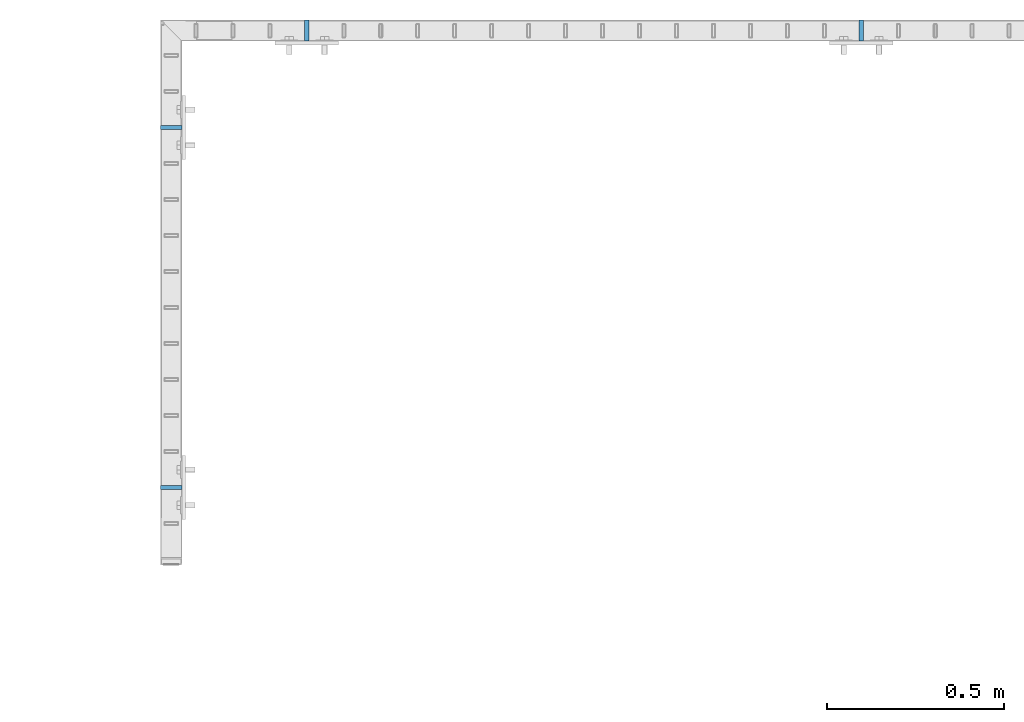
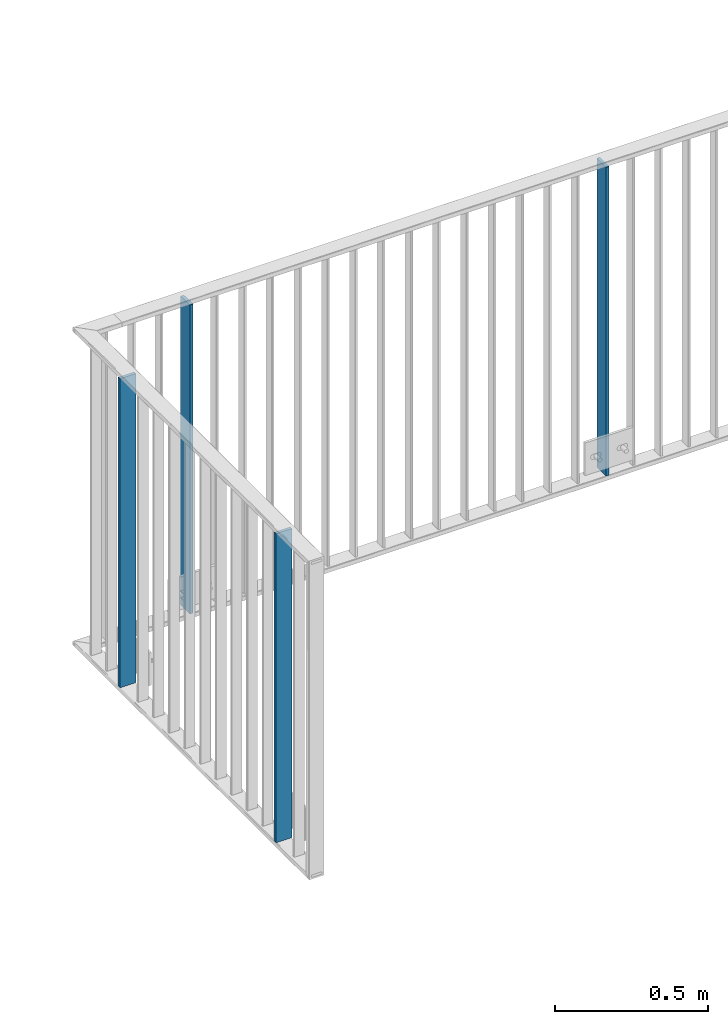
# One storey, part 41 of 156: 4 plates, 2 elements without a shape of their own.
"""IFC2X3 building model written with IfcOpenShell, lengths in millimetres."""

from ifc_helpers import new_model, si_unit, frame, origin_with_axes, origin_2d_with_axis, place, context, subcontext, project, spatial, rectangle, extrude, material, type_object, element, aggregate, save


model = new_model("IFC2X3")

# Units and contexts
model_context = context("Model", 3, precision=1e-05, world=origin_with_axes())
body_context = subcontext(model_context, "Body", "Model", "MODEL_VIEW")
ifc_project = project(units=[si_unit("LENGTHUNIT", "METRE", prefix="MILLI"), si_unit("AREAUNIT", "SQUARE_METRE"), si_unit("VOLUMEUNIT", "CUBIC_METRE"), si_unit("MASSUNIT", "GRAM", prefix="KILO"), si_unit("TIMEUNIT", "SECOND"), si_unit("PLANEANGLEUNIT", "RADIAN"), si_unit("SOLIDANGLEUNIT", "STERADIAN"), si_unit("THERMODYNAMICTEMPERATUREUNIT", "DEGREE_CELSIUS"), si_unit("LUMINOUSINTENSITYUNIT", "LUMEN")], contexts=[model_context])

# Site, building, storey
site_placement = place(None, origin_with_axes())
site = spatial("IfcSite", under=ifc_project, at=site_placement, CompositionType="ELEMENT")
building_placement = place(site_placement, origin_with_axes())
building = spatial("IfcBuilding", under=site, at=building_placement, Name="Undefined", CompositionType="ELEMENT")
storey_placement = place(building_placement, origin_with_axes())
storey = spatial("IfcBuildingStorey", under=building, at=storey_placement, Name="Undefined", CompositionType="ELEMENT", Elevation=0.0)

# Assembly, plate
assembly_1_placement = place(storey_placement, origin_with_axes())
assembly_1 = element("IfcElementAssembly", 1, at=assembly_1_placement, inside=storey, AssemblyPlace="NOTDEFINED", PredefinedType="RIGID_FRAME")
ifc_material = material(Name="STEEL/S235JR")
plate_type = type_object("IfcPlateType", PredefinedType="NOTDEFINED")
plate_1_placement = place(assembly_1_placement, frame((21874.9983592497, 22766.5810137578, 3980.00000000003), z_axis=(1.0, 0.0, 0.0), x_axis=(0.0, 0.0, -1.0)))
plate_1 = element("IfcPlate", 2, at=plate_1_placement, type_object=plate_type, material=ifc_material, context=body_context, shape_type="SweptSolid", body=[
    extrude(rectangle(XDim=12.0, YDim=60.0, at=origin_2d_with_axis()), frame((1230.0, 0.0, 0.0), z_axis=(-1.0, 0.0, 0.0), x_axis=(0.0, -1.0, 0.0)), (0.0, 0.0, 1.0), 1230.0),
])

# Assembly, plates
assembly_2_placement = place(storey_placement, origin_with_axes())
assembly_2 = element("IfcElementAssembly", 3, at=assembly_2_placement, inside=storey, AssemblyPlace="NOTDEFINED", PredefinedType="RIGID_FRAME")
plate_2_placement = place(assembly_2_placement, frame((23825.3401831972, 24057.9916060596, 3980.00000000003), z_axis=(0.0, -1.0, 0.0), x_axis=(0.0, 0.0, -1.0)))
plate_2 = element("IfcPlate", 4, at=plate_2_placement, type_object=plate_type, material=ifc_material, context=body_context, shape_type="SweptSolid", body=[
    extrude(rectangle(XDim=12.0, YDim=60.0, at=origin_2d_with_axis()), frame((1230.0, 0.0, 0.0), z_axis=(-1.0, 0.0, 0.0), x_axis=(0.0, -1.0, 0.0)), (0.0, 0.0, 1.0), 1230.0),
])
plate_3_placement = place(assembly_2_placement, frame((22258.3187312877, 24057.9916060596, 3980.00000000003), z_axis=(0.0, -1.0, 0.0), x_axis=(0.0, 0.0, -1.0)))
plate_3 = element("IfcPlate", 5, at=plate_3_placement, type_object=plate_type, material=ifc_material, context=body_context, shape_type="SweptSolid", body=[
    extrude(rectangle(XDim=12.0, YDim=60.0, at=origin_2d_with_axis()), frame((1230.0, 0.0, 0.0), z_axis=(-1.0, 0.0, 0.0), x_axis=(0.0, -1.0, 0.0)), (0.0, 0.0, 1.0), 1230.0),
])
aggregate(assembly_2, [plate_2, plate_3])

# Plate
plate_4_placement = place(assembly_1_placement, frame((21874.9983592497, 23784.4303835178, 3980.00000000003), z_axis=(1.0, 0.0, 0.0), x_axis=(0.0, 0.0, -1.0)))
plate_4 = element("IfcPlate", 6, at=plate_4_placement, type_object=plate_type, material=ifc_material, context=body_context, shape_type="SweptSolid", body=[
    extrude(rectangle(XDim=12.0, YDim=60.0, at=origin_2d_with_axis()), frame((1230.0, 0.0, 0.0), z_axis=(-1.0, 0.0, 0.0), x_axis=(0.0, -1.0, 0.0)), (0.0, 0.0, 1.0), 1230.0),
])

aggregate(assembly_1, [plate_1, plate_4])

save(model, "model.ifc")
